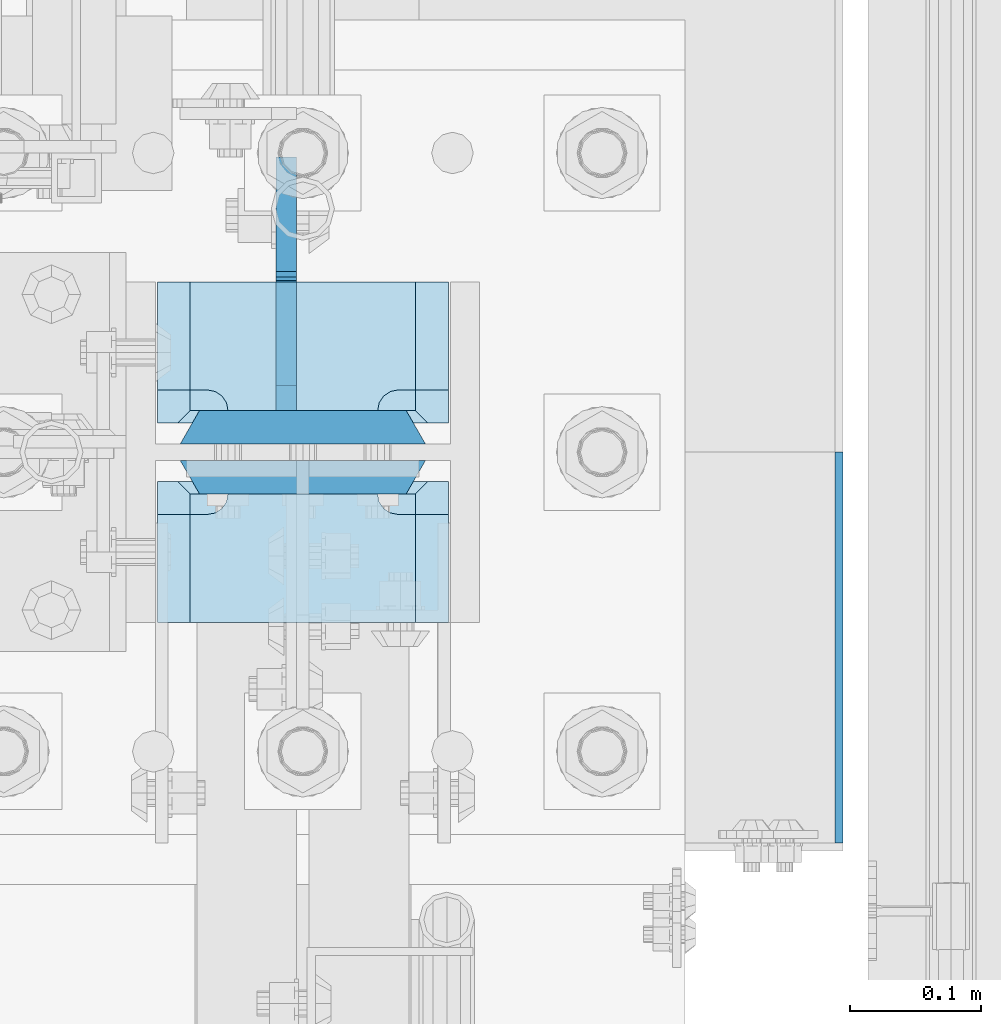
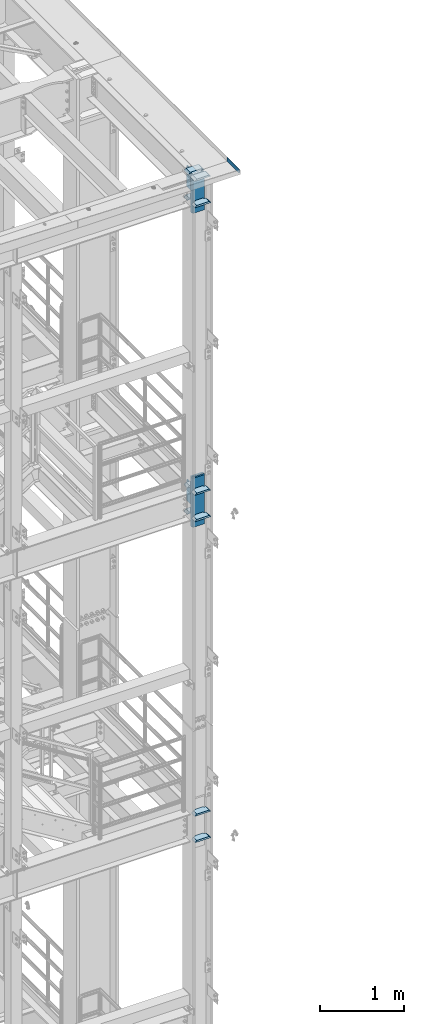
# One storey, part 1520 of 1876: 17 plates, 3 elements without a shape of their own.
"""IFC2X3 building model written with IfcOpenShell, lengths in millimetres."""

from ifc_helpers import new_model, si_unit, frame, origin_with_axes, place, context, subcontext, project, spatial, faceted_brep, material, type_object, element, aggregate, save


model = new_model("IFC2X3")

# Units and contexts
model_context = context("Model", 3, precision=1e-05, world=origin_with_axes())
body_context = subcontext(model_context, "Body", "Model", "MODEL_VIEW")
ifc_project = project(units=[si_unit("LENGTHUNIT", "METRE", prefix="MILLI"), si_unit("AREAUNIT", "SQUARE_METRE"), si_unit("VOLUMEUNIT", "CUBIC_METRE"), si_unit("MASSUNIT", "GRAM", prefix="KILO"), si_unit("TIMEUNIT", "SECOND"), si_unit("PLANEANGLEUNIT", "RADIAN"), si_unit("SOLIDANGLEUNIT", "STERADIAN"), si_unit("THERMODYNAMICTEMPERATUREUNIT", "DEGREE_CELSIUS"), si_unit("LUMINOUSINTENSITYUNIT", "LUMEN")], contexts=[model_context])

# Site, building, storey
site_placement = place(None, origin_with_axes())
site = spatial("IfcSite", under=ifc_project, at=site_placement, CompositionType="ELEMENT")
building_placement = place(site_placement, origin_with_axes())
building = spatial("IfcBuilding", under=site, at=building_placement, Name="Undefined", CompositionType="ELEMENT")
storey_placement = place(building_placement, origin_with_axes())
storey = spatial("IfcBuildingStorey", under=building, at=storey_placement, Name="Undefined", CompositionType="ELEMENT", Elevation=0.0)

# Assembly, plates
assembly_1_placement = place(storey_placement, origin_with_axes())
assembly_1 = element("IfcElementAssembly", 1, at=assembly_1_placement, inside=storey, Name="COLUMN", AssemblyPlace="NOTDEFINED", PredefinedType="RIGID_FRAME")
ifc_material_1 = material(Name="STEEL/A572-GR.50")
plate_type_1 = type_object("IfcPlateType", PredefinedType="NOTDEFINED")
plate_1_placement = place(assembly_1_placement, frame((7731.125, -7143.75, 17586.325012207), z_axis=(-1.0, 0.0, 0.0), x_axis=(0.0, -1.0, 0.0)))
plate_1 = element("IfcPlate", 2, at=plate_1_placement, type_object=plate_type_1, material=ifc_material_1, Name="PLATE", context=body_context, shape_type="Brep", body=[
    faceted_brep([(98.4250030517578, -12.7000000000007, 222.25), (98.4250030517578, 12.7000000000007, 197.150000002177), (15.875, 12.7000000000007, 197.150000002177), (15.875, -12.7000000000007, 222.25), (14.6665875786157, -12.7000000000007, 178.074902037082), (15.875, -12.7000000000007, 184.150001525879), (15.875, 12.7000000000007, 184.150001525879), (14.6665875786157, 12.7000000000007, 178.074902037082), (11.2253201513358, -12.7000000000007, 172.924681374541), (11.2253201513358, 12.7000000000007, 172.924681374541), (6.07509948879488, -12.7000000000007, 169.483413947261), (6.07509948879488, 12.7000000000007, 169.483413947261), (0.0, -12.7000000000007, 168.275001525879), (0.0, 12.7000000000007, 168.275001525879), (0.0, -12.7000000000007, 53.9749984741211), (0.0, 12.7000000000007, 53.9749984741211), (6.07509948879579, -12.7000000000007, 52.7665860527377), (6.07509948879579, 12.7000000000007, 52.7665860527377), (11.2253201513367, -12.7000000000007, 49.3253186254576), (11.2253201513367, 12.7000000000007, 49.3253186254576), (14.6665875786166, -12.7000000000007, 44.1750979629169), (14.6665875786166, 12.7000000000007, 44.1750979629169), (15.875, -12.7000000000007, 38.0999984741211), (15.875, 12.7000000000007, 38.0999984741211), (15.875, 12.7000000000007, 25.0999999978233), (15.875, -12.7000000000007, 0.0), (98.4250030517578, 12.7000000000007, 25.0999999978233), (98.4250030517578, -12.7000000000007, 0.0)], [[[0, 1, 2, 3]], [[4, 5, 6, 7]], [[8, 4, 7, 9]], [[10, 8, 9, 11]], [[12, 10, 11, 13]], [[14, 12, 13, 15]], [[16, 14, 15, 17]], [[18, 16, 17, 19]], [[20, 18, 19, 21]], [[22, 20, 21, 23]], [[22, 23, 24, 25]], [[26, 27, 25, 24]], [[5, 4, 8, 10, 12, 14, 16, 18, 20, 22, 25, 27, 0, 3]], [[6, 5, 3, 2]], [[26, 24, 23, 21, 19, 17, 15, 13, 11, 9, 7, 6, 2, 1]], [[27, 26, 1, 0]]]),
])
plate_2_placement = place(assembly_1_placement, frame((7731.125, -7143.75, 17970.5), z_axis=(-1.0, 0.0, 0.0), x_axis=(0.0, -1.0, 0.0)))
plate_2 = element("IfcPlate", 3, at=plate_2_placement, type_object=plate_type_1, material=ifc_material_1, Name="PLATE", context=body_context, shape_type="Brep", body=[
    faceted_brep([(98.4250030517578, -12.7000000000007, 222.25), (98.4250030517578, 12.7000000000007, 197.150000002177), (15.875, 12.7000000000007, 197.150000002177), (15.875, -12.7000000000007, 222.25), (14.6665875786157, -12.7000000000007, 178.074902037082), (15.875, -12.7000000000007, 184.150001525879), (15.875, 12.7000000000007, 184.150001525879), (14.6665875786157, 12.7000000000007, 178.074902037082), (11.2253201513358, -12.7000000000007, 172.924681374541), (11.2253201513358, 12.7000000000007, 172.924681374541), (6.07509948879488, -12.7000000000007, 169.483413947261), (6.07509948879488, 12.7000000000007, 169.483413947261), (0.0, -12.7000000000007, 168.275001525879), (0.0, 12.7000000000007, 168.275001525879), (0.0, -12.7000000000007, 53.9749984741211), (0.0, 12.7000000000007, 53.9749984741211), (6.07509948879579, -12.7000000000007, 52.7665860527377), (6.07509948879579, 12.7000000000007, 52.7665860527377), (11.2253201513367, -12.7000000000007, 49.3253186254576), (11.2253201513367, 12.7000000000007, 49.3253186254576), (14.6665875786166, -12.7000000000007, 44.1750979629169), (14.6665875786166, 12.7000000000007, 44.1750979629169), (15.875, -12.7000000000007, 38.0999984741211), (15.875, 12.7000000000007, 38.0999984741211), (15.875, 12.7000000000007, 25.0999999978233), (15.875, -12.7000000000007, 0.0), (98.4250030517578, 12.7000000000007, 25.0999999978233), (98.4250030517578, -12.7000000000007, 0.0)], [[[0, 1, 2, 3]], [[4, 5, 6, 7]], [[8, 4, 7, 9]], [[10, 8, 9, 11]], [[12, 10, 11, 13]], [[14, 12, 13, 15]], [[16, 14, 15, 17]], [[18, 16, 17, 19]], [[20, 18, 19, 21]], [[22, 20, 21, 23]], [[22, 23, 24, 25]], [[26, 27, 25, 24]], [[5, 4, 8, 10, 12, 14, 16, 18, 20, 22, 25, 27, 0, 3]], [[6, 5, 3, 2]], [[26, 24, 23, 21, 19, 17, 15, 13, 11, 9, 7, 6, 2, 1]], [[27, 26, 1, 0]]]),
])
plate_3_placement = place(assembly_1_placement, frame((7731.125, -6981.825, 17586.325012207), z_axis=(-1.0, 0.0, 0.0), x_axis=(0.0, -1.0, 0.0)))
plate_3 = element("IfcPlate", 4, at=plate_3_placement, type_object=plate_type_1, material=ifc_material_1, Name="PLATE", context=body_context, shape_type="Brep", body=[
    faceted_brep([(82.5500030517578, -12.7000000000007, 222.25), (82.5500030517578, 12.7000000000007, 197.150000002177), (0.0, 12.7000000000007, 197.150000002177), (0.0, -12.7000000000007, 222.25), (82.5500030517578, 12.7000000000007, 25.0999999978233), (82.5500030517578, -12.7000000000007, 0.0), (0.0, -12.6999999999998, 0.0), (0.0, 12.7000000000007, 25.0999999978233), (82.5500030517578, 12.7000000000007, 38.0999984741211), (82.5500030517578, -12.7000000000007, 38.0999984741211), (83.7584154731412, -12.7000000000007, 44.1750979629169), (83.7584154731412, 12.7000000000007, 44.1750979629169), (87.1996829004211, -12.7000000000007, 49.3253186254576), (87.1996829004211, 12.7000000000007, 49.3253186254576), (92.349903562962, -12.7000000000007, 52.7665860527377), (92.349903562962, 12.7000000000007, 52.7665860527377), (98.4250030517578, -12.7000000000007, 53.9749984741211), (98.4250030517578, 12.7000000000007, 53.9749984741211), (98.4250030517578, -12.7000000000007, 168.275001525879), (98.4250030517578, 12.7000000000007, 168.275001525879), (92.349903562962, -12.7000000000007, 169.483413947262), (92.349903562962, 12.7000000000007, 169.483413947262), (87.1996829004211, -12.7000000000007, 172.924681374543), (87.1996829004211, 12.7000000000007, 172.924681374543), (83.7584154731412, -12.7000000000007, 178.074902037083), (83.7584154731412, 12.7000000000007, 178.074902037083), (82.5500030517578, -12.7000000000007, 184.150001525879), (82.5500030517578, 12.7000000000007, 184.150001525879)], [[[0, 1, 2, 3]], [[4, 5, 6, 7]], [[8, 9, 5, 4]], [[10, 9, 8, 11]], [[12, 10, 11, 13]], [[14, 12, 13, 15]], [[16, 14, 15, 17]], [[18, 16, 17, 19]], [[20, 18, 19, 21]], [[22, 20, 21, 23]], [[24, 22, 23, 25]], [[26, 24, 25, 27]], [[6, 5, 9, 10, 12, 14, 16, 18, 20, 22, 24, 26, 0, 3]], [[7, 6, 3, 2]], [[27, 25, 23, 21, 19, 17, 15, 13, 11, 8, 4, 7, 2, 1]], [[26, 27, 1, 0]]]),
])
plate_4_placement = place(assembly_1_placement, frame((7731.125, -6981.825, 17970.5), z_axis=(-1.0, 0.0, 0.0), x_axis=(0.0, -1.0, 0.0)))
plate_4 = element("IfcPlate", 5, at=plate_4_placement, type_object=plate_type_1, material=ifc_material_1, Name="PLATE", context=body_context, shape_type="Brep", body=[
    faceted_brep([(82.5500030517578, -12.7000000000007, 222.25), (82.5500030517578, 12.7000000000007, 197.150000002177), (0.0, 12.7000000000007, 197.150000002177), (0.0, -12.7000000000007, 222.25), (82.5500030517578, 12.7000000000007, 25.0999999978233), (82.5500030517578, -12.7000000000007, 0.0), (0.0, -12.6999999999998, 0.0), (0.0, 12.7000000000007, 25.0999999978233), (82.5500030517578, 12.7000000000007, 38.0999984741211), (82.5500030517578, -12.7000000000007, 38.0999984741211), (83.7584154731412, -12.7000000000007, 44.1750979629169), (83.7584154731412, 12.7000000000007, 44.1750979629169), (87.1996829004211, -12.7000000000007, 49.3253186254576), (87.1996829004211, 12.7000000000007, 49.3253186254576), (92.349903562962, -12.7000000000007, 52.7665860527377), (92.349903562962, 12.7000000000007, 52.7665860527377), (98.4250030517578, -12.7000000000007, 53.9749984741211), (98.4250030517578, 12.7000000000007, 53.9749984741211), (98.4250030517578, -12.7000000000007, 168.275001525879), (98.4250030517578, 12.7000000000007, 168.275001525879), (92.349903562962, -12.7000000000007, 169.483413947262), (92.349903562962, 12.7000000000007, 169.483413947262), (87.1996829004211, -12.7000000000007, 172.924681374543), (87.1996829004211, 12.7000000000007, 172.924681374543), (83.7584154731412, -12.7000000000007, 178.074902037083), (83.7584154731412, 12.7000000000007, 178.074902037083), (82.5500030517578, -12.7000000000007, 184.150001525879), (82.5500030517578, 12.7000000000007, 184.150001525879)], [[[0, 1, 2, 3]], [[4, 5, 6, 7]], [[8, 9, 5, 4]], [[10, 9, 8, 11]], [[12, 10, 11, 13]], [[14, 12, 13, 15]], [[16, 14, 15, 17]], [[18, 16, 17, 19]], [[20, 18, 19, 21]], [[22, 20, 21, 23]], [[24, 22, 23, 25]], [[26, 24, 25, 27]], [[6, 5, 9, 10, 12, 14, 16, 18, 20, 22, 24, 26, 0, 3]], [[7, 6, 3, 2]], [[27, 25, 23, 21, 19, 17, 15, 13, 11, 8, 4, 7, 2, 1]], [[26, 27, 1, 0]]]),
])
ifc_material_2 = material(Name="STEEL/A572-50")
plate_5_placement = place(assembly_1_placement, frame((7731.125, -7143.75, 22158.325012207), z_axis=(-1.0, 0.0, 0.0), x_axis=(0.0, -1.0, 0.0)))
plate_5 = element("IfcPlate", 6, at=plate_5_placement, type_object=plate_type_1, material=ifc_material_2, Name="PLATE", context=body_context, shape_type="Brep", body=[
    faceted_brep([(98.4250030517578, -12.7000000000007, 222.25), (98.4250030517578, 12.7000000000007, 197.150000002177), (15.875, 12.7000000000007, 197.150000002177), (15.875, -12.7000000000007, 222.25), (14.6665875786157, -12.7000000000007, 178.074902037082), (15.875, -12.7000000000007, 184.150001525879), (15.875, 12.7000000000007, 184.150001525879), (14.6665875786157, 12.7000000000007, 178.074902037082), (11.2253201513358, -12.7000000000007, 172.924681374541), (11.2253201513358, 12.7000000000007, 172.924681374541), (6.07509948879488, -12.7000000000007, 169.483413947261), (6.07509948879488, 12.7000000000007, 169.483413947261), (0.0, -12.7000000000007, 168.275001525879), (0.0, 12.7000000000007, 168.275001525879), (0.0, -12.7000000000007, 53.9749984741211), (0.0, 12.7000000000007, 53.9749984741211), (6.07509948879579, -12.7000000000007, 52.7665860527377), (6.07509948879579, 12.7000000000007, 52.7665860527377), (11.2253201513367, -12.7000000000007, 49.3253186254576), (11.2253201513367, 12.7000000000007, 49.3253186254576), (14.6665875786166, -12.7000000000007, 44.1750979629169), (14.6665875786166, 12.7000000000007, 44.1750979629169), (15.875, -12.7000000000007, 38.0999984741211), (15.875, 12.7000000000007, 38.0999984741211), (15.875, 12.7000000000007, 25.0999999978233), (15.875, -12.7000000000007, 0.0), (98.4250030517578, 12.7000000000007, 25.0999999978233), (98.4250030517578, -12.7000000000007, 0.0)], [[[0, 1, 2, 3]], [[4, 5, 6, 7]], [[8, 4, 7, 9]], [[10, 8, 9, 11]], [[12, 10, 11, 13]], [[14, 12, 13, 15]], [[16, 14, 15, 17]], [[18, 16, 17, 19]], [[20, 18, 19, 21]], [[22, 20, 21, 23]], [[22, 23, 24, 25]], [[26, 27, 25, 24]], [[5, 4, 8, 10, 12, 14, 16, 18, 20, 22, 25, 27, 0, 3]], [[6, 5, 3, 2]], [[26, 24, 23, 21, 19, 17, 15, 13, 11, 9, 7, 6, 2, 1]], [[27, 26, 1, 0]]]),
])
plate_6_placement = place(assembly_1_placement, frame((7731.125, -6981.825, 22158.325012207), z_axis=(-1.0, 0.0, 0.0), x_axis=(0.0, -1.0, 0.0)))
plate_6 = element("IfcPlate", 7, at=plate_6_placement, type_object=plate_type_1, material=ifc_material_2, Name="PLATE", context=body_context, shape_type="Brep", body=[
    faceted_brep([(82.5500030517578, -12.7000000000007, 222.25), (82.5500030517578, 12.7000000000007, 197.150000002177), (0.0, 12.7000000000007, 197.150000002177), (0.0, -12.7000000000007, 222.25), (82.5500030517578, 12.7000000000007, 25.0999999978233), (82.5500030517578, -12.7000000000007, 0.0), (0.0, -12.6999999999998, 0.0), (0.0, 12.7000000000007, 25.0999999978233), (82.5500030517578, 12.7000000000007, 38.0999984741211), (82.5500030517578, -12.7000000000007, 38.0999984741211), (83.7584154731412, -12.7000000000007, 44.1750979629169), (83.7584154731412, 12.7000000000007, 44.1750979629169), (87.1996829004211, -12.7000000000007, 49.3253186254576), (87.1996829004211, 12.7000000000007, 49.3253186254576), (92.349903562962, -12.7000000000007, 52.7665860527377), (92.349903562962, 12.7000000000007, 52.7665860527377), (98.4250030517578, -12.7000000000007, 53.9749984741211), (98.4250030517578, 12.7000000000007, 53.9749984741211), (98.4250030517578, -12.7000000000007, 168.275001525879), (98.4250030517578, 12.7000000000007, 168.275001525879), (92.349903562962, -12.7000000000007, 169.483413947262), (92.349903562962, 12.7000000000007, 169.483413947262), (87.1996829004211, -12.7000000000007, 172.924681374543), (87.1996829004211, 12.7000000000007, 172.924681374543), (83.7584154731412, -12.7000000000007, 178.074902037083), (83.7584154731412, 12.7000000000007, 178.074902037083), (82.5500030517578, -12.7000000000007, 184.150001525879), (82.5500030517578, 12.7000000000007, 184.150001525879)], [[[0, 1, 2, 3]], [[4, 5, 6, 7]], [[8, 9, 5, 4]], [[10, 9, 8, 11]], [[12, 10, 11, 13]], [[14, 12, 13, 15]], [[16, 14, 15, 17]], [[18, 16, 17, 19]], [[20, 18, 19, 21]], [[22, 20, 21, 23]], [[24, 22, 23, 25]], [[26, 24, 25, 27]], [[6, 5, 9, 10, 12, 14, 16, 18, 20, 22, 24, 26, 0, 3]], [[7, 6, 3, 2]], [[27, 25, 23, 21, 19, 17, 15, 13, 11, 8, 4, 7, 2, 1]], [[26, 27, 1, 0]]]),
])

assembly_2_placement = place(storey_placement, origin_with_axes())
assembly_2 = element("IfcElementAssembly", 8, at=assembly_2_placement, inside=storey, Name="COLUMN", AssemblyPlace="NOTDEFINED", PredefinedType="RIGID_FRAME")
plate_7_placement = place(assembly_2_placement, frame((7731.125, -7143.75, 12912.725012207), z_axis=(-1.0, 0.0, 0.0), x_axis=(0.0, -1.0, 0.0)))
plate_7 = element("IfcPlate", 9, at=plate_7_placement, type_object=plate_type_1, material=ifc_material_1, Name="PLATE", context=body_context, shape_type="Brep", body=[
    faceted_brep([(98.4250030517578, -12.7000000000007, 222.25), (98.4250030517578, 12.7000000000007, 197.150000002177), (15.875, 12.7000000000007, 197.150000002177), (15.875, -12.7000000000007, 222.25), (14.6665875786157, -12.7000000000007, 178.074902037082), (15.875, -12.7000000000007, 184.150001525879), (15.875, 12.7000000000007, 184.150001525879), (14.6665875786157, 12.7000000000007, 178.074902037082), (11.2253201513358, -12.7000000000007, 172.924681374541), (11.2253201513358, 12.7000000000007, 172.924681374541), (6.07509948879488, -12.7000000000007, 169.483413947261), (6.07509948879488, 12.7000000000007, 169.483413947261), (0.0, -12.7000000000007, 168.275001525879), (0.0, 12.7000000000007, 168.275001525879), (0.0, -12.7000000000007, 53.9749984741211), (0.0, 12.7000000000007, 53.9749984741211), (6.07509948879579, -12.7000000000007, 52.7665860527377), (6.07509948879579, 12.7000000000007, 52.7665860527377), (11.2253201513367, -12.7000000000007, 49.3253186254576), (11.2253201513367, 12.7000000000007, 49.3253186254576), (14.6665875786166, -12.7000000000007, 44.1750979629169), (14.6665875786166, 12.7000000000007, 44.1750979629169), (15.875, -12.7000000000007, 38.0999984741211), (15.875, 12.7000000000007, 38.0999984741211), (15.875, 12.7000000000007, 25.0999999978233), (15.875, -12.7000000000007, 0.0), (98.4250030517578, 12.7000000000007, 25.0999999978233), (98.4250030517578, -12.7000000000007, 0.0)], [[[0, 1, 2, 3]], [[4, 5, 6, 7]], [[8, 4, 7, 9]], [[10, 8, 9, 11]], [[12, 10, 11, 13]], [[14, 12, 13, 15]], [[16, 14, 15, 17]], [[18, 16, 17, 19]], [[20, 18, 19, 21]], [[22, 20, 21, 23]], [[22, 23, 24, 25]], [[26, 27, 25, 24]], [[5, 4, 8, 10, 12, 14, 16, 18, 20, 22, 25, 27, 0, 3]], [[6, 5, 3, 2]], [[26, 24, 23, 21, 19, 17, 15, 13, 11, 9, 7, 6, 2, 1]], [[27, 26, 1, 0]]]),
])
plate_8_placement = place(assembly_2_placement, frame((7731.125, -7143.75, 13296.9), z_axis=(-1.0, 0.0, 0.0), x_axis=(0.0, -1.0, 0.0)))
plate_8 = element("IfcPlate", 10, at=plate_8_placement, type_object=plate_type_1, material=ifc_material_1, Name="PLATE", context=body_context, shape_type="Brep", body=[
    faceted_brep([(98.4250030517578, -12.7000000000007, 222.25), (98.4250030517578, 12.7000000000007, 197.150000002177), (15.875, 12.7000000000007, 197.150000002177), (15.875, -12.7000000000007, 222.25), (14.6665875786157, -12.7000000000007, 178.074902037082), (15.875, -12.7000000000007, 184.150001525879), (15.875, 12.7000000000007, 184.150001525879), (14.6665875786157, 12.7000000000007, 178.074902037082), (11.2253201513358, -12.7000000000007, 172.924681374541), (11.2253201513358, 12.7000000000007, 172.924681374541), (6.07509948879488, -12.7000000000007, 169.483413947261), (6.07509948879488, 12.7000000000007, 169.483413947261), (0.0, -12.7000000000007, 168.275001525879), (0.0, 12.7000000000007, 168.275001525879), (0.0, -12.7000000000007, 53.9749984741211), (0.0, 12.7000000000007, 53.9749984741211), (6.07509948879579, -12.7000000000007, 52.7665860527377), (6.07509948879579, 12.7000000000007, 52.7665860527377), (11.2253201513367, -12.7000000000007, 49.3253186254576), (11.2253201513367, 12.7000000000007, 49.3253186254576), (14.6665875786166, -12.7000000000007, 44.1750979629169), (14.6665875786166, 12.7000000000007, 44.1750979629169), (15.875, -12.7000000000007, 38.0999984741211), (15.875, 12.7000000000007, 38.0999984741211), (15.875, 12.7000000000007, 25.0999999978233), (15.875, -12.7000000000007, 0.0), (98.4250030517578, 12.7000000000007, 25.0999999978233), (98.4250030517578, -12.7000000000007, 0.0)], [[[0, 1, 2, 3]], [[4, 5, 6, 7]], [[8, 4, 7, 9]], [[10, 8, 9, 11]], [[12, 10, 11, 13]], [[14, 12, 13, 15]], [[16, 14, 15, 17]], [[18, 16, 17, 19]], [[20, 18, 19, 21]], [[22, 20, 21, 23]], [[22, 23, 24, 25]], [[26, 27, 25, 24]], [[5, 4, 8, 10, 12, 14, 16, 18, 20, 22, 25, 27, 0, 3]], [[6, 5, 3, 2]], [[26, 24, 23, 21, 19, 17, 15, 13, 11, 9, 7, 6, 2, 1]], [[27, 26, 1, 0]]]),
])
aggregate(assembly_2, [plate_7, plate_8])

# Plate
plate_type_2 = type_object("IfcPlateType", PredefinedType="NOTDEFINED")
plate_9_placement = place(assembly_1_placement, frame((7526.3375, -7131.05, 18135.6), z_axis=(1.0, 0.0, 0.0), x_axis=(0.0, 0.0, -1.0)))
plate_9 = element("IfcPlate", 11, at=plate_9_placement, type_object=plate_type_2, material=ifc_material_1, Name="PLATE", context=body_context, shape_type="Brep", body=[
    faceted_brep([(0.0, -12.6999999999998, 172.660303166218), (714.375, -12.6999999999998, 172.660303166232), (714.375, 12.6999999999998, 187.324996948242), (0.0, 12.6999999999998, 187.324996948242), (714.375, -12.6999999999998, 14.6646968337647), (714.375, 12.6999999999998, 0.0), (0.0, 12.6999999999998, 0.0), (0.0, -12.6999999999998, 14.6646968337648)], [[[0, 1, 2, 3]], [[2, 1, 4, 5]], [[3, 2, 5, 6]], [[0, 3, 6, 7]], [[1, 0, 7, 4]], [[6, 5, 4, 7]]]),
])

plate_10_placement = place(assembly_1_placement, frame((7526.3375, -7092.95, 18135.6), z_axis=(1.0, 0.0, 0.0), x_axis=(0.0, 0.0, -1.0)))
plate_10 = element("IfcPlate", 12, at=plate_10_placement, type_object=plate_type_2, material=ifc_material_1, Name="PLATE", context=body_context, shape_type="Brep", body=[
    faceted_brep([(0.0, 12.6999999999998, 172.66030316161), (0.0, -12.6999999999998, 187.324996948242), (714.375, -12.6999999999998, 187.324996948242), (714.375, 12.6999999999998, 172.660303161603), (714.375, 12.6999999999998, 14.6646968384017), (0.0, 12.6999999999998, 14.6646968383725), (0.0, -12.6999999999998, 0.0), (714.375, -12.6999999999998, 0.0)], [[[0, 1, 2, 3]], [[0, 3, 4, 5]], [[1, 0, 5, 6]], [[2, 1, 6, 7]], [[3, 2, 7, 4]], [[6, 5, 4, 7]]]),
])

plate_11_placement = place(assembly_1_placement, frame((7526.3375, -7092.95, 22529.8), z_axis=(1.0, 0.0, 0.0), x_axis=(0.0, 0.0, -1.0)))
plate_11 = element("IfcPlate", 13, at=plate_11_placement, type_object=plate_type_2, material=ifc_material_1, Name="PLATE", context=body_context, shape_type="Brep", body=[
    faceted_brep([(0.0, 12.6999999999998, 172.66030316161), (0.0, -12.6999999999998, 187.324996948242), (536.575012207031, -12.6999999999998, 187.324996948242), (536.575012207031, 12.6999999999998, 172.66030316161), (536.575012207031, 12.6999999999998, 14.6646968383725), (0.0, 12.6999999999998, 14.6646968383725), (0.0, -12.6999999999998, 0.0), (536.575012207031, -12.6999999999998, 0.0)], [[[0, 1, 2, 3]], [[0, 3, 4, 5]], [[1, 0, 5, 6]], [[2, 1, 6, 7]], [[3, 2, 7, 4]], [[6, 5, 4, 7]]]),
])

plate_12_placement = place(assembly_1_placement, frame((7526.3375, -7131.05, 22529.8), z_axis=(1.0, 0.0, 0.0), x_axis=(0.0, 0.0, -1.0)))
plate_12 = element("IfcPlate", 14, at=plate_12_placement, type_object=plate_type_2, material=ifc_material_1, Name="PLATE", context=body_context, shape_type="Brep", body=[
    faceted_brep([(0.0, -12.6999999999998, 172.660303166218), (536.575012207031, -12.6999999999998, 172.660303166218), (536.575012207031, 12.6999999999998, 187.324996948242), (0.0, 12.6999999999998, 187.324996948242), (536.575012207031, -12.6999999999998, 14.6646968337648), (536.575012207031, 12.6999999999998, 0.0), (0.0, 12.6999999999998, 0.0), (0.0, -12.6999999999998, 14.6646968337648)], [[[0, 1, 2, 3]], [[2, 1, 4, 5]], [[3, 2, 5, 6]], [[0, 3, 6, 7]], [[1, 0, 7, 4]], [[6, 5, 4, 7]]]),
])

plate_type_3 = type_object("IfcPlateType", PredefinedType="NOTDEFINED")
plate_13_placement = place(assembly_1_placement, frame((7731.125, -7118.35, 22542.5), z_axis=(-1.0, 0.0, 0.0), x_axis=(0.0, -1.0, 0.0)))
plate_13 = element("IfcPlate", 15, at=plate_13_placement, type_object=plate_type_3, material=ifc_material_2, Name="PLATE", context=body_context, shape_type="Brep", body=[
    faceted_brep([(123.824996948242, -12.5499999989115, 222.40000000109), (123.824996948242, 12.7000000000007, 197.15000000218), (25.4000000000024, 12.7000000000007, 197.15000000218), (15.875, 3.17499999999563, 206.675000002184), (15.875, -12.7000000000007, 222.25), (14.6665875786157, -12.7000000000007, 178.074902037082), (15.875, -12.7000000000007, 184.150001525879), (15.875, 3.17499999999563, 184.150001525879), (14.6665875786157, 1.96658757861223, 178.074902037082), (11.2253201513358, -12.7000000000007, 172.924681374541), (11.2253201513358, -1.47467984866671, 172.924681374541), (6.07509948879488, -12.7000000000007, 169.483413947261), (6.07509948879488, -6.62490051120767, 169.483413947261), (0.0, -12.7000000000007, 168.275001525879), (6.07509948879579, -12.7000000000007, 52.7665860527377), (0.0, -12.7000000000007, 53.9749984741211), (6.07509948879579, -6.62490051120767, 52.7665860527377), (11.2253201513367, -12.7000000000007, 49.3253186254576), (11.2253201513367, -1.47467984866671, 49.3253186254576), (14.6665875786166, -12.7000000000007, 44.1750979629169), (14.6665875786166, 1.96658757861223, 44.1750979629169), (15.875, -12.7000000000007, 38.0999984741211), (15.875, 3.17499999999563, 38.0999984741211), (15.875, 3.17499999999563, 15.6499999983591), (15.875, -12.7000000000007, 0.0), (123.824996948242, 12.7000000000007, 25.1749999983624), (123.824996948242, -12.7000000000007, 0.0), (25.4000000000024, 12.7000000000007, 25.1749999983624)], [[[0, 1, 2, 3, 4]], [[5, 6, 7, 8]], [[9, 5, 8, 10]], [[11, 9, 10, 12]], [[11, 12, 13]], [[14, 15, 16]], [[17, 14, 16, 18]], [[19, 17, 18, 20]], [[21, 19, 20, 22]], [[21, 22, 23, 24]], [[25, 26, 24, 23, 27]], [[6, 5, 9, 11, 13, 15, 14, 17, 19, 21, 24, 26, 0, 4]], [[7, 6, 4, 3]], [[27, 23, 22, 20, 18, 16, 15, 13, 12, 10, 8, 7, 3, 2]], [[25, 27, 2, 1]], [[26, 25, 1, 0]]]),
])

plate_14_placement = place(assembly_1_placement, frame((7731.125, -6981.825, 22542.5), z_axis=(-1.0, 0.0, 0.0), x_axis=(0.0, -1.0, 0.0)))
plate_14 = element("IfcPlate", 16, at=plate_14_placement, type_object=plate_type_3, material=ifc_material_2, Name="PLATE", context=body_context, shape_type="Brep", body=[
    faceted_brep([(107.950004577637, -12.7000000000007, 222.25), (107.950004577637, 3.17499829605367, 206.675001706127), (98.4250030517578, 12.7000000000007, 197.150000002177), (0.0, 12.7000000000007, 197.150000002177), (0.0, -12.7000000000007, 222.25), (107.950004577637, 3.17499829605367, 15.5749982938728), (107.950004577637, -12.7000000000007, 0.0), (0.0, -12.6999999999998, 0.0), (0.0, 12.7000000000007, 25.0999999978233), (98.4250030517578, 12.7000000000007, 25.0999999978233), (107.950004577637, 3.17499829605367, 38.0999984741211), (107.950004577637, -12.7000000000007, 38.0999984741211), (109.15841699902, -12.7000000000007, 44.1750979629169), (109.15841699902, 1.96658565592224, 44.1750979629169), (112.5996844263, -12.7000000000007, 49.3253186254576), (112.5996844263, -1.47468239429145, 49.3253186254576), (117.749905088841, -12.7000000000007, 52.7665860527377), (117.749905088841, -6.62490398912269, 52.7665860527377), (123.825004577637, -12.7000000000007, 53.9749984741211), (117.749905088841, -12.7000000000007, 169.483413947262), (123.825004577637, -12.7000000000007, 168.275001525879), (117.749905088841, -6.62490398912269, 169.483413947262), (112.5996844263, -12.7000000000007, 172.924681374543), (112.5996844263, -1.47468239429145, 172.924681374543), (109.15841699902, -12.7000000000007, 178.074902037083), (109.15841699902, 1.96658565592588, 178.074902037083), (107.950004577637, -12.7000000000007, 184.150001525879), (107.950004577637, 3.17499829605367, 184.150001525879)], [[[0, 1, 2, 3, 4]], [[5, 6, 7, 8, 9]], [[10, 11, 6, 5]], [[12, 11, 10, 13]], [[14, 12, 13, 15]], [[16, 14, 15, 17]], [[16, 17, 18]], [[19, 20, 21]], [[22, 19, 21, 23]], [[24, 22, 23, 25]], [[26, 24, 25, 27]], [[7, 6, 11, 12, 14, 16, 18, 20, 19, 22, 24, 26, 0, 4]], [[8, 7, 4, 3]], [[9, 8, 3, 2]], [[27, 25, 23, 21, 20, 18, 17, 15, 13, 10, 5, 9, 2, 1]], [[26, 27, 1, 0]]]),
])

# Assembly, plate
assembly_3_placement = place(storey_placement, origin_with_axes())
assembly_3 = element("IfcElementAssembly", 17, at=assembly_3_placement, inside=storey, Name="BENT PLATE", AssemblyPlace="NOTDEFINED", PredefinedType="RIGID_FRAME")
ifc_material_3 = material(Name="STEEL/A36")
plate_type_4 = type_object("IfcPlateType", PredefinedType="NOTDEFINED")
plate_15_placement = place(assembly_3_placement, frame((8029.57499999996, -7410.44995117231, 22561.5478278329), z_axis=(4.95800000044255e-06, 7.19900000513007e-06, 0.999999999961796), x_axis=(0.0, 0.999999999968684, -7.91400000071008e-06)))
plate_15 = element("IfcPlate", 18, at=plate_15_placement, type_object=plate_type_4, material=ifc_material_3, Name="PLATE", context=body_context, shape_type="Brep", body=[
    faceted_brep([(-0.000244549460148846, -3.17500000000382, 19.0499992354526), (-0.000774413767430815, -3.17500000001746, 60.3255538939302), (-0.000774413763792836, 3.17499999998017, 60.3255538939375), (-0.000244549461058341, 3.17499999999382, 19.0499992354635), (298.449523925901, -3.17500000001746, 60.3277206420316), (298.449523925905, 3.17499999998017, 60.3277206420426), (298.44995117201, -3.17499999999745, -1.81898940354586e-11), (298.449951172007, 3.17499999999836, -1.09139364212751e-11), (19.0499992370706, -3.17499999999745, -3.63797880709171e-12), (19.0499992370678, 3.17499999999836, 3.63797880709171e-12)], [[[0, 1, 2, 3]], [[1, 4, 5, 2]], [[4, 6, 7, 5]], [[6, 8, 9, 7]], [[8, 0, 3, 9]], [[5, 7, 9, 3, 2]], [[8, 6, 4, 1, 0]]]),
])
aggregate(assembly_3, [plate_15])

# Plate
plate_type_5 = type_object("IfcPlateType", PredefinedType="NOTDEFINED")
plate_16_placement = place(assembly_1_placement, frame((7607.3, -7080.25, 17957.8), z_axis=(0.0, 1.0, 0.0), x_axis=(0.0, 0.0, -1.0)))
plate_16 = element("IfcPlate", 19, at=plate_16_placement, type_object=plate_type_5, material=ifc_material_2, Name="PLATE", context=body_context, shape_type="Brep", body=[
    faceted_brep([(317.499526107607, -7.9375, 193.675002687783), (317.499987728603, -7.9375, 111.124768999664), (317.499987728603, 7.9375, 111.124768999664), (317.499526107607, 7.9375, 193.675003051758), (318.466744828744, -7.9375, 106.264694887646), (318.466744828744, 7.9375, 106.264694887646), (321.21978176921, -7.9375, 102.144533814409), (321.21978176921, 7.9375, 102.144533814409), (325.339973632152, -7.9375, 99.3915429540011), (325.339973632152, 7.9375, 99.3915429540011), (330.200058556071, -7.9375, 98.4248402089934), (330.200058556071, 7.9375, 98.4248402089934), (358.774999999998, -7.9375, 98.4249999999993), (358.774993896484, 7.9375, 98.4249999999993), (12.7000000839216, -7.9375, 193.674999999999), (12.7000000839216, 7.9375, 193.675003051758), (12.7000000839216, 7.9375, 111.124999809264), (12.7000000839216, -7.9375, 111.124999809264), (11.7332701613341, 7.9375, 106.264920291219), (11.7332701613341, -7.9375, 106.264920291219), (8.98025626085655, 7.9375, 102.144743823065), (8.98025626085655, -7.9375, 102.144743823065), (4.86007979270289, 7.9375, 99.3917299225868), (4.86007979270289, -7.9375, 99.3917299225868), (0.0, 7.9375, 98.4249999999993), (0.0, -7.9375, 98.4249999999993), (0.0, 7.9375, 0.0), (0.0, -7.9375, 0.0), (358.774993896484, -7.9375, 0.0), (358.774993896484, 7.9375, 0.0)], [[[0, 1, 2, 3]], [[4, 5, 2, 1]], [[6, 7, 5, 4]], [[8, 9, 7, 6]], [[10, 11, 9, 8]], [[12, 13, 11, 10]], [[14, 15, 16, 17]], [[17, 16, 18, 19]], [[19, 18, 20, 21]], [[21, 20, 22, 23]], [[23, 22, 24, 25]], [[26, 27, 25, 24]], [[28, 27, 26, 29]], [[8, 6, 4, 1, 0, 14, 17, 19, 21, 23, 25, 27, 28, 12, 10]], [[15, 14, 0, 3]], [[29, 26, 24, 22, 20, 18, 16, 15, 3, 2, 5, 7, 9, 11, 13]], [[28, 29, 13, 12]]]),
])

plate_17_placement = place(assembly_1_placement, frame((7607.30049991608, -7080.25, 22529.8), z_axis=(0.0, 1.0, 0.0), x_axis=(0.0, 0.0, -1.0)))
plate_17 = element("IfcPlate", 20, at=plate_17_placement, type_object=plate_type_5, material=ifc_material_2, Name="PLATE", context=body_context, shape_type="Brep", body=[
    faceted_brep([(317.499526107607, -7.9375, 193.675002687783), (317.499987728603, -7.9375, 111.124768999664), (317.499987728603, 7.9375, 111.124768999664), (317.499526107607, 7.9375, 193.675003051758), (318.466744828744, -7.9375, 106.264694887646), (318.466744828744, 7.9375, 106.264694887646), (321.21978176921, -7.9375, 102.144533814409), (321.21978176921, 7.9375, 102.144533814409), (325.339973632152, -7.9375, 99.3915429540011), (325.339973632152, 7.9375, 99.3915429540011), (330.200058556071, -7.9375, 98.4248402089934), (330.200058556071, 7.9375, 98.4248402089934), (358.774999999998, -7.9375, 98.4249999999993), (358.774993896484, 7.9375, 98.4249999999993), (12.7000000839216, -7.9375, 193.674999999999), (12.7000000839216, 7.9375, 193.675003051758), (12.7000000839216, 7.9375, 111.124999809264), (12.7000000839216, -7.9375, 111.124999809264), (11.7332701613341, 7.9375, 106.264920291219), (11.7332701613341, -7.9375, 106.264920291219), (8.98025626085655, 7.9375, 102.144743823065), (8.98025626085655, -7.9375, 102.144743823065), (4.86007979270289, 7.9375, 99.3917299225868), (4.86007979270289, -7.9375, 99.3917299225868), (0.0, 7.9375, 98.4249999999993), (0.0, -7.9375, 98.4249999999993), (0.0, 7.9375, 19.0499992370605), (0.0, -7.9375, 19.0499992370605), (19.0499992370605, -7.9375, 0.0), (19.0499992370605, 7.9375, 0.0), (339.724994659424, -7.9375, 0.0), (339.724994659424, 7.9375, 0.0), (358.774993896484, -7.9375, 19.0499992370605), (358.774993896484, 7.9375, 19.0499992370605)], [[[0, 1, 2, 3]], [[4, 5, 2, 1]], [[6, 7, 5, 4]], [[8, 9, 7, 6]], [[10, 11, 9, 8]], [[12, 13, 11, 10]], [[14, 15, 16, 17]], [[17, 16, 18, 19]], [[19, 18, 20, 21]], [[21, 20, 22, 23]], [[23, 22, 24, 25]], [[26, 27, 25, 24]], [[28, 27, 26, 29]], [[30, 28, 29, 31]], [[32, 30, 31, 33]], [[8, 6, 4, 1, 0, 14, 17, 19, 21, 23, 25, 27, 28, 30, 32, 12, 10]], [[15, 14, 0, 3]], [[33, 31, 29, 26, 24, 22, 20, 18, 16, 15, 3, 2, 5, 7, 9, 11, 13]], [[32, 33, 13, 12]]]),
])

aggregate(assembly_1, [plate_13, plate_14, plate_1, plate_2, plate_3, plate_4, plate_9, plate_10, plate_16, plate_5, plate_6, plate_17, plate_11, plate_12])

save(model, "model.ifc")
